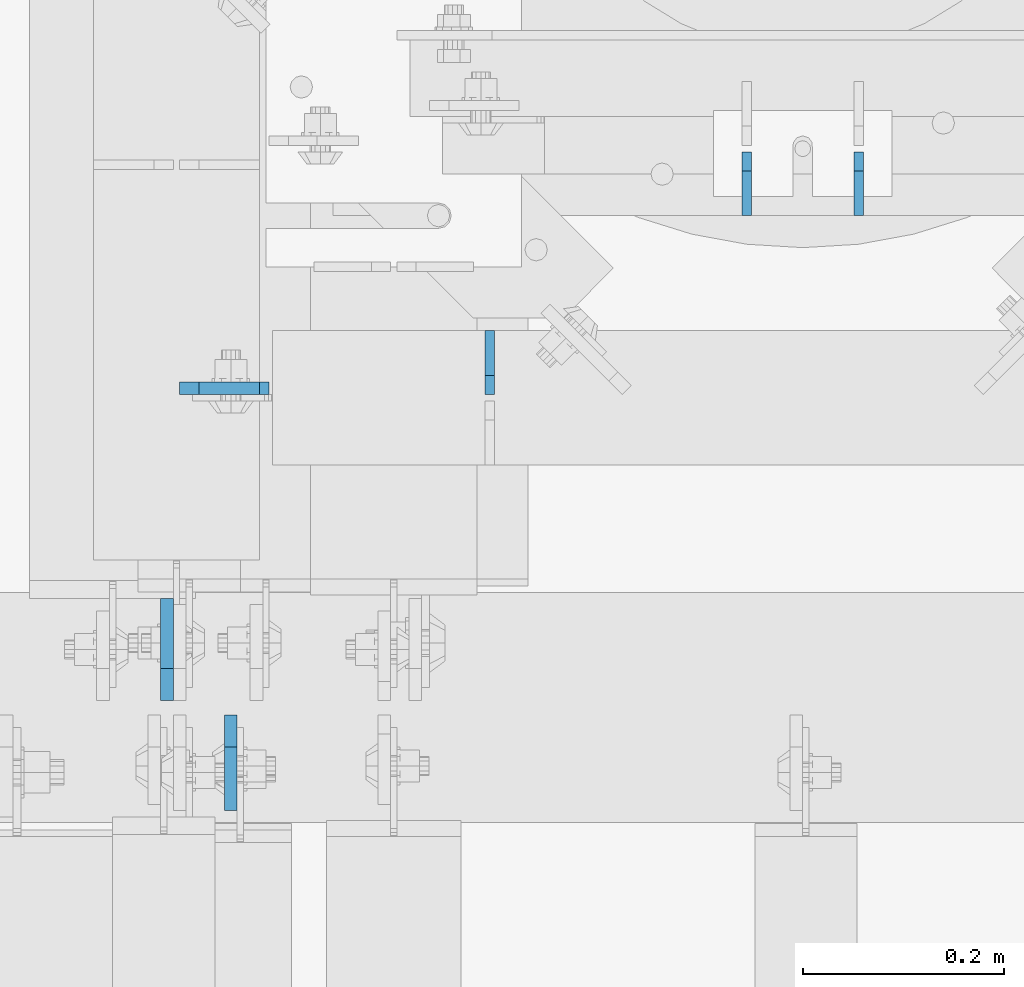
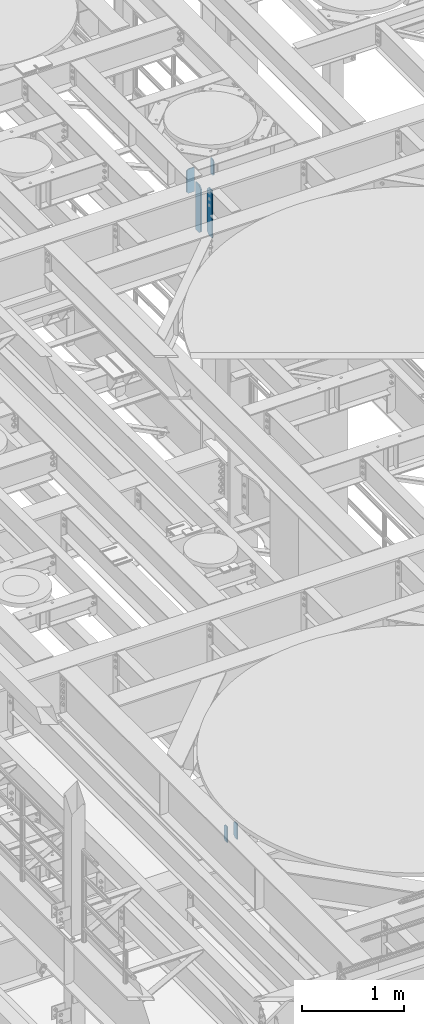
# One storey, part 1578 of 1876: 6 plates, 4 elements without a shape of their own.
"""IFC2X3 building model written with IfcOpenShell, lengths in millimetres."""

from ifc_helpers import new_model, si_unit, frame, origin_with_axes, place, context, subcontext, project, spatial, faceted_brep, material, type_object, element, aggregate, save


model = new_model("IFC2X3")

# Units and contexts
model_context = context("Model", 3, precision=1e-05, world=origin_with_axes())
body_context = subcontext(model_context, "Body", "Model", "MODEL_VIEW")
ifc_project = project(units=[si_unit("LENGTHUNIT", "METRE", prefix="MILLI"), si_unit("AREAUNIT", "SQUARE_METRE"), si_unit("VOLUMEUNIT", "CUBIC_METRE"), si_unit("MASSUNIT", "GRAM", prefix="KILO"), si_unit("TIMEUNIT", "SECOND"), si_unit("PLANEANGLEUNIT", "RADIAN"), si_unit("SOLIDANGLEUNIT", "STERADIAN"), si_unit("THERMODYNAMICTEMPERATUREUNIT", "DEGREE_CELSIUS"), si_unit("LUMINOUSINTENSITYUNIT", "LUMEN")], contexts=[model_context])

# Site, building, storey
site_placement = place(None, origin_with_axes())
site = spatial("IfcSite", under=ifc_project, at=site_placement, CompositionType="ELEMENT")
building_placement = place(site_placement, origin_with_axes())
building = spatial("IfcBuilding", under=site, at=building_placement, Name="Undefined", CompositionType="ELEMENT")
storey_placement = place(building_placement, origin_with_axes())
storey = spatial("IfcBuildingStorey", under=building, at=storey_placement, Name="Undefined", CompositionType="ELEMENT", Elevation=0.0)

# Assembly, plates
assembly_1_placement = place(storey_placement, origin_with_axes())
assembly_1 = element("IfcElementAssembly", 1, at=assembly_1_placement, inside=storey, Name="BEAM", AssemblyPlace="NOTDEFINED", PredefinedType="RIGID_FRAME")
ifc_material = material(Name="STEEL/A36")
plate_type_1 = type_object("IfcPlateType", PredefinedType="NOTDEFINED")
plate_1_placement = place(assembly_1_placement, frame((4364.0375, 2012.95, 4932.3625), z_axis=(0.0, 0.0, 1.0), x_axis=(0.0, 1.0, 0.0)))
plate_1 = element("IfcPlate", 2, at=plate_1_placement, type_object=plate_type_1, material=ifc_material, Name="PLATE", context=body_context, shape_type="Brep", body=[
    faceted_brep([(0.0, -4.76249999999982, 0.0), (0.0, -4.76249999999982, 190.5), (0.0, 4.76249999999982, 190.5), (0.0, 4.76249999999982, 0.0), (44.4500007629395, -4.76249999999982, 190.5), (44.4500007629395, 4.76249999999982, 190.5), (63.5, -4.76249999999982, 171.450000762939), (63.5, 4.76249999999982, 171.450000762939), (63.5, -4.76249999999982, 19.0499992370605), (63.5, 4.76249999999982, 19.0499992370605), (44.4500007629395, -4.76249999999982, 0.0), (44.4500007629395, 4.76249999999982, 0.0)], [[[0, 1, 2, 3]], [[1, 4, 5, 2]], [[4, 6, 7, 5]], [[6, 8, 9, 7]], [[8, 10, 11, 9]], [[10, 0, 3, 11]], [[5, 7, 9, 11, 3, 2]], [[10, 8, 6, 4, 1, 0]]]),
])
plate_2_placement = place(assembly_1_placement, frame((4475.1625, 2012.95, 4932.3625), z_axis=(0.0, 0.0, 1.0), x_axis=(0.0, 1.0, 0.0)))
plate_2 = element("IfcPlate", 3, at=plate_2_placement, type_object=plate_type_1, material=ifc_material, Name="PLATE", context=body_context, shape_type="Brep", body=[
    faceted_brep([(0.0, -4.76249999999982, 0.0), (0.0, -4.76249999999982, 190.5), (0.0, 4.76249999999982, 190.5), (0.0, 4.76249999999982, 0.0), (44.4500007629395, -4.76249999999982, 190.5), (44.4500007629395, 4.76249999999982, 190.5), (63.5, -4.76249999999982, 171.450000762939), (63.5, 4.76249999999982, 171.450000762939), (63.5, -4.76249999999982, 19.0499992370605), (63.5, 4.76249999999982, 19.0499992370605), (44.4500007629395, -4.76249999999982, 0.0), (44.4500007629395, 4.76249999999982, 0.0)], [[[0, 1, 2, 3]], [[1, 4, 5, 2]], [[4, 6, 7, 5]], [[6, 8, 9, 7]], [[8, 10, 11, 9]], [[10, 0, 3, 11]], [[5, 7, 9, 11, 3, 2]], [[10, 8, 6, 4, 1, 0]]]),
])
aggregate(assembly_1, [plate_1, plate_2])

# Assembly, plate
assembly_2_placement = place(storey_placement, origin_with_axes())
assembly_2 = element("IfcElementAssembly", 4, at=assembly_2_placement, inside=storey, Name="BEAM", AssemblyPlace="NOTDEFINED", PredefinedType="RIGID_FRAME")
plate_3_placement = place(assembly_2_placement, frame((4108.45, 1835.15, 13111.1625), z_axis=(0.0, 0.0, 1.0), x_axis=(0.0, 1.0, 0.0)))
plate_3 = element("IfcPlate", 5, at=plate_3_placement, type_object=plate_type_1, material=ifc_material, Name="PLATE", context=body_context, shape_type="Brep", body=[
    faceted_brep([(0.0, -4.76249999999982, 19.0499992370605), (0.0, -4.76249999999982, 171.450000762939), (0.0, 4.76249999999982, 171.450000762939), (0.0, 4.76249999999982, 19.0499992370605), (19.0499992370605, -4.76249999999982, 190.5), (19.0499992370605, 4.76249999999982, 190.5), (63.5, -4.76249999999982, 190.5), (63.5, 4.76249999999982, 190.5), (63.5, -4.76249999999982, 0.0), (63.5, 4.76249999999982, 0.0), (19.0499992370605, -4.76249999999982, 0.0), (19.0499992370605, 4.76249999999982, 0.0)], [[[0, 1, 2, 3]], [[1, 4, 5, 2]], [[4, 6, 7, 5]], [[6, 8, 9, 7]], [[8, 10, 11, 9]], [[10, 0, 3, 11]], [[5, 7, 9, 11, 3, 2]], [[10, 8, 6, 4, 1, 0]]]),
])
aggregate(assembly_2, [plate_3])

assembly_3_placement = place(storey_placement, origin_with_axes())
assembly_3 = element("IfcElementAssembly", 6, at=assembly_3_placement, inside=storey, Name="BEAM", AssemblyPlace="NOTDEFINED", PredefinedType="RIGID_FRAME")
plate_type_2 = type_object("IfcPlateType", PredefinedType="NOTDEFINED")
plate_4_placement = place(assembly_3_placement, frame((3800.475, 1841.50000009537, 13007.975), z_axis=(0.0, 0.0, 1.0), x_axis=(1.0, 0.0, 0.0)))
plate_4 = element("IfcPlate", 7, at=plate_4_placement, type_object=plate_type_2, material=ifc_material, Name="PLATE", context=body_context, shape_type="Brep", body=[
    faceted_brep([(0.0, -6.35000000000036, 271.462512969971), (19.0499992370605, -6.35000000000036, 290.512512207031), (19.0499992370605, 6.35000000000036, 290.512512207031), (0.0, 6.35000000000036, 271.462512969971), (0.0, -6.35000000000196, 19.0499992370605), (0.0, 6.35000000000105, 19.0499992370605), (19.0499992370642, -6.35000000000105, 0.0), (19.0499992370633, 6.35000000000105, 0.0), (88.9000015258789, -6.34999999999991, 0.0), (88.9000015258789, 6.34999999999991, 0.0), (88.9000015258789, -6.34999999999991, 280.987512151783), (79.3749874887271, -6.35000000000036, 290.512512207031), (79.3749874887271, 6.35000000000036, 290.512512207031), (88.9000015258789, 6.34999999999991, 280.987512151783)], [[[0, 1, 2, 3]], [[4, 0, 3, 5]], [[6, 4, 5, 7]], [[8, 6, 7, 9]], [[1, 0, 4, 6, 8, 10, 11]], [[2, 1, 11, 12]], [[9, 7, 5, 3, 2, 12, 13]], [[8, 9, 13, 10]], [[12, 11, 10, 13]]]),
])
aggregate(assembly_3, [plate_4])

# Assembly, plates
assembly_4_placement = place(storey_placement, origin_with_axes())
assembly_4 = element("IfcElementAssembly", 8, at=assembly_4_placement, inside=storey, Name="BEAM", AssemblyPlace="NOTDEFINED", PredefinedType="RIGID_FRAME")
plate_type_3 = type_object("IfcPlateType", PredefinedType="NOTDEFINED")
plate_5_placement = place(assembly_4_placement, frame((3851.27499990463, 1516.85625, 12714.2875), z_axis=(0.0, 0.0, 1.0), x_axis=(0.0, -1.0, 0.0)))
plate_5 = element("IfcPlate", 9, at=plate_5_placement, type_object=plate_type_3, material=ifc_material, Name="PLATE", context=body_context, shape_type="Brep", body=[
    faceted_brep([(0.0, -6.34999999999991, 31.75), (0.0, -6.35000000000036, 538.162475585938), (0.0, 6.35000000000036, 538.162475585938), (0.0, 6.34999999999991, 31.75), (31.75, -6.35000000000036, 569.912475585938), (31.75, 6.35000000000036, 569.912475585938), (95.25, -6.35000000000036, 569.912475585938), (95.25, 6.35000000000036, 569.912475585938), (95.25, -6.35000000000036, 0.0), (95.25, 6.35000000000036, 0.0), (31.75, -6.34999999999991, 0.0), (31.75, 6.34999999999991, 0.0)], [[[0, 1, 2, 3]], [[1, 4, 5, 2]], [[4, 6, 7, 5]], [[6, 8, 9, 7]], [[8, 10, 11, 9]], [[10, 0, 3, 11]], [[5, 7, 9, 11, 3, 2]], [[10, 8, 6, 4, 1, 0]]]),
])
plate_type_4 = type_object("IfcPlateType", PredefinedType="NOTDEFINED")
plate_6_placement = place(assembly_4_placement, frame((3787.77499990463, 1531.14375, 12714.2875), z_axis=(0.0, 0.0, 1.0), x_axis=(0.0, 1.0, 0.0)))
plate_6 = element("IfcPlate", 10, at=plate_6_placement, type_object=plate_type_4, material=ifc_material, Name="PLATE", context=body_context, shape_type="Brep", body=[
    faceted_brep([(0.0, -6.34999999999991, 31.75), (0.0, -6.35000000000036, 538.162475585938), (0.0, 6.35000000000036, 538.162475585938), (0.0, 6.34999999999991, 31.75), (31.75, -6.35000000000036, 569.912475585938), (31.75, 6.35000000000036, 569.912475585938), (101.599998474121, -6.34999999999991, 569.912475585938), (101.599998474121, 6.34999999999991, 569.912475585938), (101.599998474121, -6.35000000000036, 0.0), (101.599998474121, 6.35000000000036, 0.0), (31.75, -6.34999999999991, 0.0), (31.75, 6.34999999999991, 0.0)], [[[0, 1, 2, 3]], [[1, 4, 5, 2]], [[4, 6, 7, 5]], [[6, 8, 9, 7]], [[8, 10, 11, 9]], [[10, 0, 3, 11]], [[5, 7, 9, 11, 3, 2]], [[10, 8, 6, 4, 1, 0]]]),
])
aggregate(assembly_4, [plate_6, plate_5])

save(model, "model.ifc")
